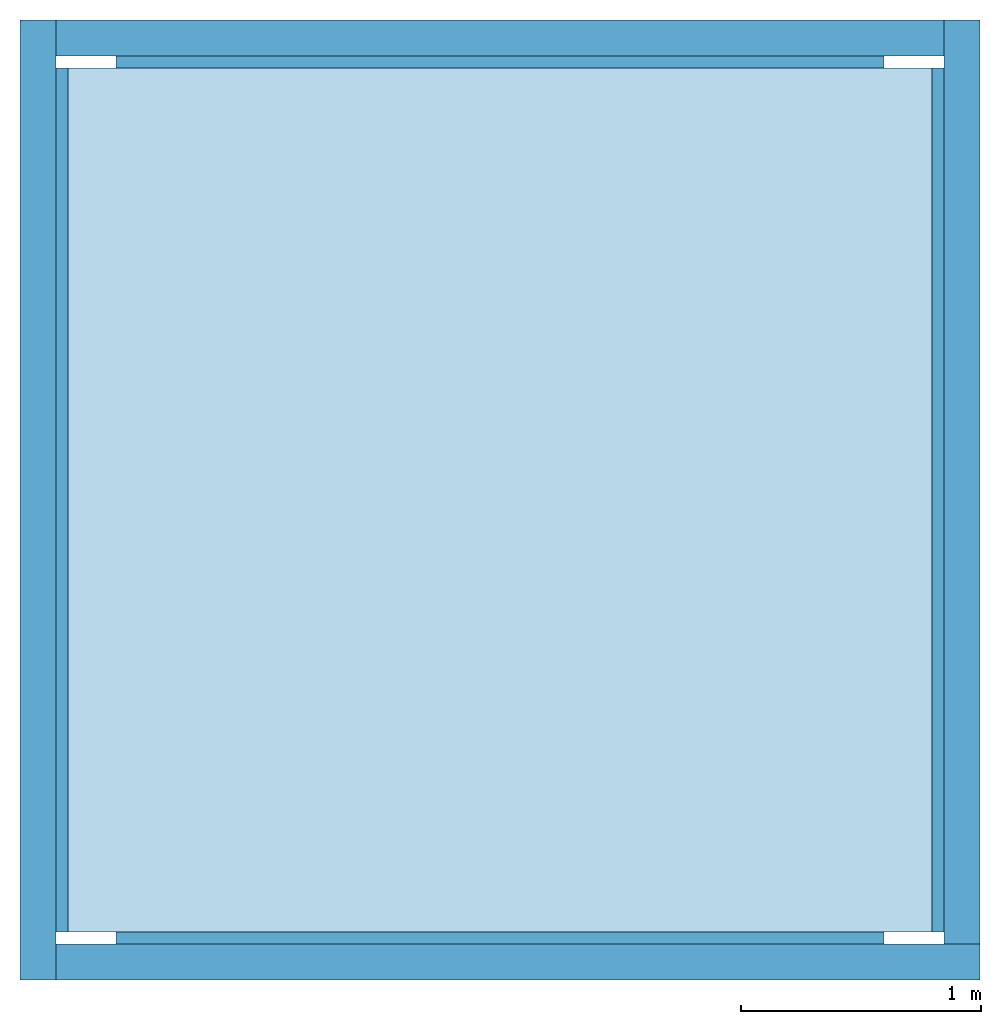
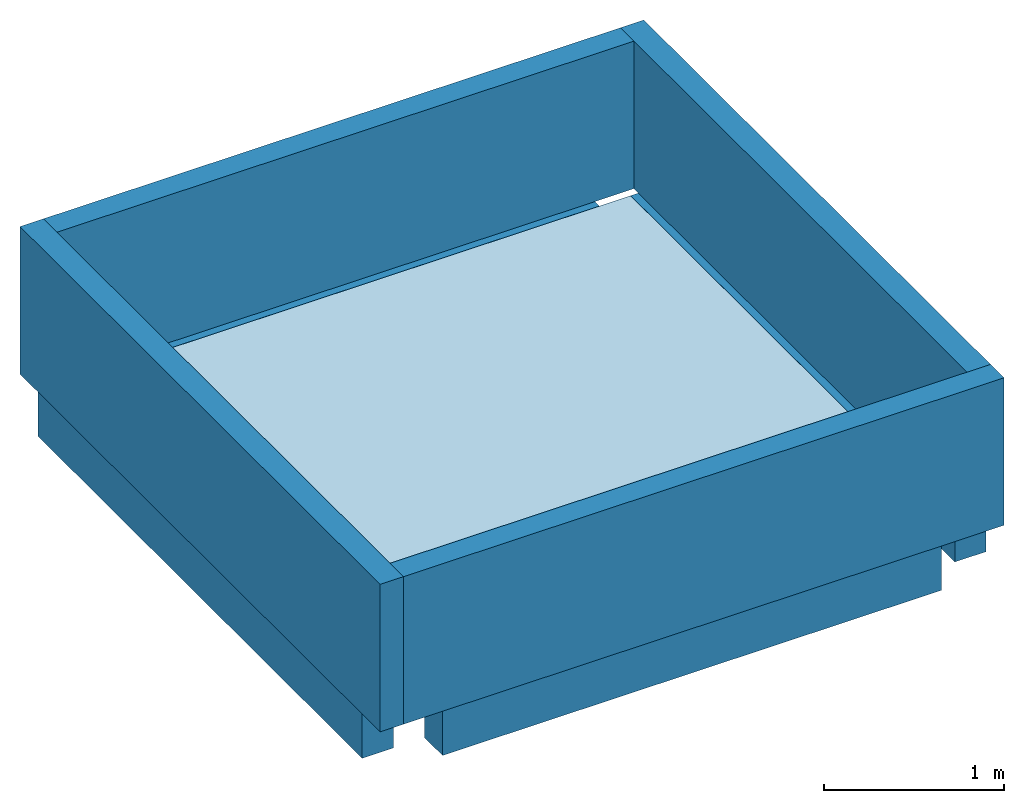
# One storey: 4 beams, 4 walls, 1 slab.
"""IFC4 building model written with IfcOpenShell, lengths in metres."""

from ifc_helpers import new_model, entity, si_unit, converted_unit, frame, origin_with_axes, origin_2d_with_axis, place, context, subcontext, project, spatial, line, indexed_curve, rectangle, outline, extrude, material, layer, layer_set, layer_usage, material_profile, profile_set, profile_usage, type_object, element, save


model = new_model("IFC4")

# Units and contexts
model_context = context("Model", 3, precision=1e-05, world=origin_with_axes())
plan_context = context("Plan", 2, precision=1e-05, world=origin_2d_with_axis())
body_context = subcontext(model_context, "Body", "Model", "MODEL_VIEW")
ifc_project = project(units=[si_unit("VOLUMEUNIT", "CUBIC_METRE"), si_unit("LENGTHUNIT", "METRE"), converted_unit("PLANEANGLEUNIT", "degree", entity("IfcReal", 0.0174532925199433), si_unit("PLANEANGLEUNIT", "RADIAN"), dimensions=[0, 0, 0, 0, 0, 0, 0]), si_unit("AREAUNIT", "SQUARE_METRE")], contexts=[model_context, plan_context])

# Site, building, storey
site_placement = place(None, origin_with_axes())
site = spatial("IfcSite", under=ifc_project, at=site_placement)
building_placement = place(site_placement, origin_with_axes())
building = spatial("IfcBuilding", under=site, at=building_placement)
storey_placement = place(building_placement, frame((0.0, 0.0, 3.15000009536743), z_axis=(0.0, 0.0, 1.0), x_axis=(1.0, 0.0, 0.0)))
storey = spatial("IfcBuildingStorey", under=building, at=storey_placement, Name="1F")

# Beams
ifc_material_1 = material(Name="C30-37", Category="concrete")
ifc_material_profile = material_profile(ifc_material_1, rectangle(XDim=0.200000002980232, YDim=0.300000011920929))
ifc_profile_set = profile_set([ifc_material_profile])
ifc_profile_usage_1 = profile_usage(ifc_profile_set, cardinal=7)
beam_type = type_object("IfcBeamType", Name="BEM-01", PredefinedType="BEAM", material=ifc_profile_set)
beam_1_placement = place(storey_placement, frame((0.0, 0.200000047683716, 0.0), z_axis=(1.5099578831723e-07, 0.999999999999986, 7.54979012640422e-08), x_axis=(-0.999999999999986, 1.50995802528084e-07, -7.54979083694696e-08)))
element("IfcBeam", 1, at=beam_1_placement, inside=storey, type_object=beam_type, material=ifc_profile_usage_1, Name="Beam", context=body_context, shape_type="SweptSolid", body=[
    extrude(rectangle(XDim=0.200000002980232, YDim=0.300000011920929), frame((-0.100000001490116, -0.150000005960465, 0.0), z_axis=(0.0, 0.0, 1.0), x_axis=(1.0, 0.0, 0.0)), (0.0, 0.0, 1.0), 3.59999987284347),
])
ifc_profile_usage_2 = profile_usage(ifc_profile_set, cardinal=7)
beam_2_placement = place(storey_placement, frame((0.400000005960464, 3.99999976158142, 0.0), z_axis=(0.999999999999994, -7.54979012640429e-08, 7.54979012640429e-08), x_axis=(7.54979012640431e-08, 0.999999999999997, 7.16093850883224e-15)))
element("IfcBeam", 2, at=beam_2_placement, inside=storey, type_object=beam_type, material=ifc_profile_usage_2, Name="Beam", context=body_context, shape_type="SweptSolid", body=[
    extrude(rectangle(XDim=0.200000002980232, YDim=0.300000011920929), frame((-0.100000001490116, -0.150000005960465, 0.0), z_axis=(0.0, 0.0, 1.0), x_axis=(1.0, 0.0, 0.0)), (0.0, 0.0, 1.0), 3.19999981522561),
])
ifc_profile_usage_3 = profile_usage(ifc_profile_set, cardinal=7)
beam_3_placement = place(storey_placement, frame((4.0, 3.79999995231628, 0.0), z_axis=(-3.5762786865232e-07, -0.999999999999933, 7.54979012640383e-08), x_axis=(0.999999999999923, -3.57627868652316e-07, 1.62920684942934e-07)))
element("IfcBeam", 3, at=beam_3_placement, inside=storey, type_object=beam_type, material=ifc_profile_usage_3, Name="Beam", context=body_context, shape_type="SweptSolid", body=[
    extrude(rectangle(XDim=0.200000002980232, YDim=0.300000011920929), frame((-0.100000001490116, -0.150000005960465, 0.0), z_axis=(0.0, 0.0, 1.0), x_axis=(1.0, 0.0, 0.0)), (0.0, 0.0, 1.0), 3.59999960793416),
])
ifc_profile_usage_4 = profile_usage(ifc_profile_set, cardinal=7)
beam_4_placement = place(storey_placement, frame((3.59999990463257, 1.19209289550781e-07, 0.0), z_axis=(-0.999999999999947, 2.82129974493713e-07, -1.62920684942938e-07), x_axis=(-2.82129974493715e-07, -0.999999999999956, -8.94069813739367e-08)))
element("IfcBeam", 4, at=beam_4_placement, inside=storey, type_object=beam_type, material=ifc_profile_usage_4, Name="Beam", context=body_context, shape_type="SweptSolid", body=[
    extrude(rectangle(XDim=0.200000002980232, YDim=0.300000011920929), frame((-0.100000001490116, -0.150000005960465, 0.0), z_axis=(0.0, 0.0, 1.0), x_axis=(1.0, 0.0, 0.0)), (0.0, 0.0, 1.0), 3.20000056028377),
])

# Slab
ifc_material_2 = material(Name="C25-30", Category="concrete")
ifc_layer_1 = layer(ifc_material_2, 0.150000005960464, Name="concrete")
ifc_layer_set_1 = layer_set([ifc_layer_1], Name="raft slab")
ifc_layer_usage_1 = layer_usage(ifc_layer_set_1, "AXIS3", "POSITIVE", 0.0)
slab_type = type_object("IfcSlabType", Name="SLB-02", PredefinedType="ROOF", material=ifc_layer_set_1)
slab_placement = place(storey_placement, frame((3.79999995231628, 3.79999995231628, -0.150000095367432), z_axis=(0.0, 0.0, 1.0), x_axis=(-0.999999999999947, -3.25841369885876e-07, 0.0)))
element("IfcSlab", 5, at=slab_placement, inside=storey, type_object=slab_type, material=ifc_layer_usage_1, Name="Slab", context=body_context, shape_type="SweptSolid", body=[
    extrude(outline(indexed_curve([(0.0, 0.0), (3.59999942779541, -8.47187379804382e-07), (3.60000038146973, 3.59999895095825), (8.471874366478e-07, 3.59999966621399)], segments=[line(4, 1), line(1, 2), line(2, 3), line(3, 4)], self_intersect=False)), None, (0.0, 0.0, 1.0), 0.150000005960464),
])

# Walls
ifc_material_3 = material(Name="BLK-02", Category="masonry")
ifc_layer_2 = layer(ifc_material_3, 0.150000005960464)
ifc_layer_set_2 = layer_set([ifc_layer_2])
ifc_layer_usage_2 = layer_usage(ifc_layer_set_2, "AXIS2", "POSITIVE", 0.0)
wall_type = type_object("IfcWallType", Name="WAL-03", PredefinedType="PARAPET", material=ifc_layer_set_2)
wall_1_placement = place(storey_placement, frame((0.0, 4.0, 0.0), z_axis=(0.0, 0.0, 1.0), x_axis=(-5.2054855359522e-07, -0.999999999999865, 0.0)))
element("IfcWall", 6, at=wall_1_placement, inside=storey, type_object=wall_type, material=ifc_layer_usage_2, Name="Wall", context=body_context, shape_type="SweptSolid", body=[
    extrude(outline(indexed_curve([(0.0, 0.0), (0.0, 0.150000005960464), (3.99999809265145, 0.150000005960464), (3.99999809265145, 0.0), (0.0, 0.0)], self_intersect=False)), origin_with_axes(), (0.0, 0.0, 1.0), 1.0),
])
ifc_layer_usage_3 = layer_usage(ifc_layer_set_2, "AXIS2", "POSITIVE", 0.0)
wall_2_placement = place(storey_placement, frame((0.149997919797897, 1.9073486328125e-06, 0.0), z_axis=(0.0, 0.0, 1.0), x_axis=(0.999999999999886, -4.76837158203071e-07, 0.0)))
element("IfcWall", 7, at=wall_2_placement, inside=storey, type_object=wall_type, material=ifc_layer_usage_3, Name="Wall", context=body_context, shape_type="SweptSolid", body=[
    extrude(outline(indexed_curve([(0.0, 0.0), (0.0, 0.150000005960464), (3.85000201138574, 0.150000005960464), (3.85000201138574, 0.0), (0.0, 0.0)], self_intersect=False)), origin_with_axes(), (0.0, 0.0, 1.0), 1.0),
])
ifc_layer_usage_4 = layer_usage(ifc_layer_set_2, "AXIS2", "POSITIVE", 0.0)
wall_3_placement = place(storey_placement, frame((4.0, 0.150000095367432, 0.0), z_axis=(0.0, 0.0, 1.0), x_axis=(5.52335052361657e-07, 0.999999999999847, 0.0)))
element("IfcWall", 8, at=wall_3_placement, inside=storey, type_object=wall_type, material=ifc_layer_usage_4, Name="Wall", context=body_context, shape_type="SweptSolid", body=[
    extrude(outline(indexed_curve([(0.0, 0.0), (0.0, 0.150000005960464), (3.84999965816421, 0.150000005960464), (3.84999965816421, 0.0), (0.0, 0.0)], self_intersect=False)), origin_with_axes(), (0.0, 0.0, 1.0), 1.0),
])
ifc_layer_usage_5 = layer_usage(ifc_layer_set_2, "AXIS2", "POSITIVE", 0.0)
wall_4_placement = place(storey_placement, frame((3.85000252723694, 3.99999976158142, 0.0), z_axis=(0.0, 0.0, 1.0), x_axis=(-0.999999999999924, 3.89414367418765e-07, 0.0)))
element("IfcWall", 9, at=wall_4_placement, inside=storey, type_object=wall_type, material=ifc_layer_usage_5, Name="Wall", context=body_context, shape_type="SweptSolid", body=[
    extrude(outline(indexed_curve([(0.0, 0.0), (0.0, 0.150000005960464), (3.7000023919177, 0.150000005960464), (3.7000023919177, 0.0), (0.0, 0.0)], self_intersect=False)), origin_with_axes(), (0.0, 0.0, 1.0), 1.0),
])

save(model, "model.ifc")
